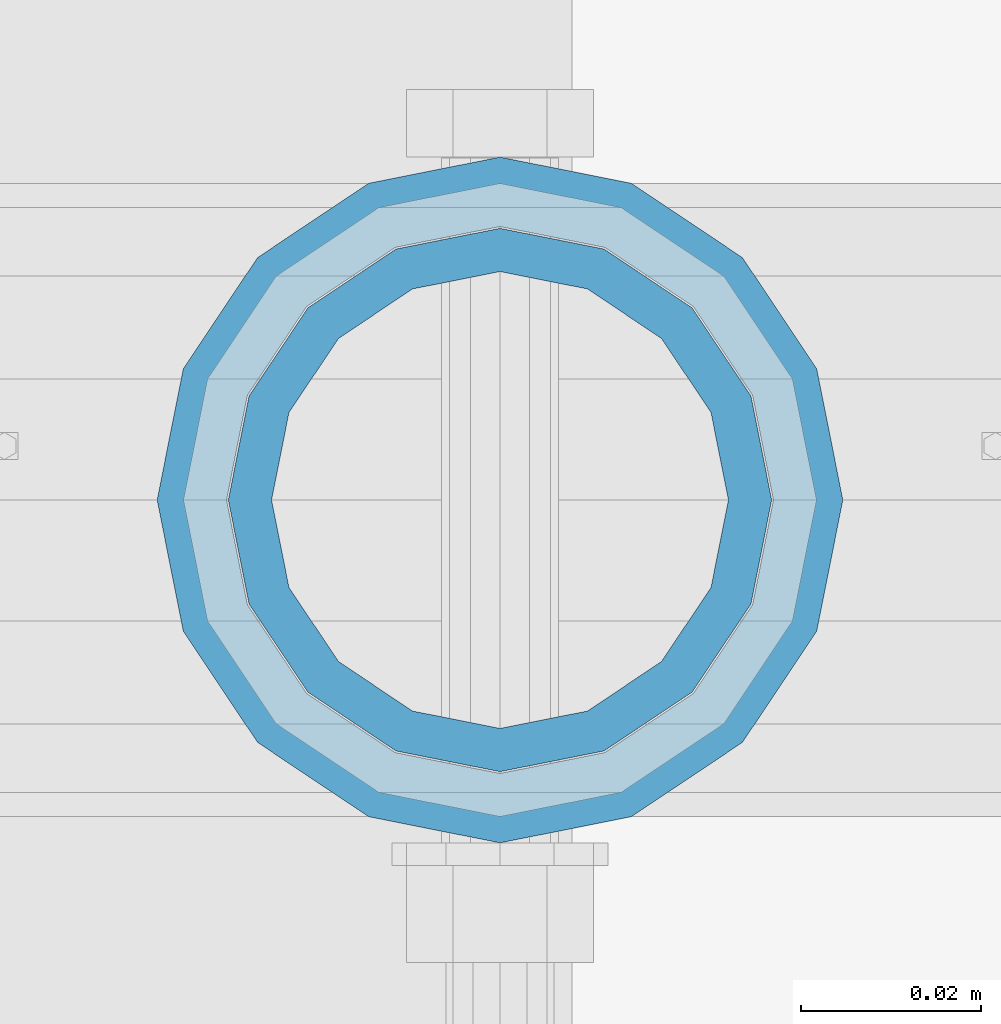
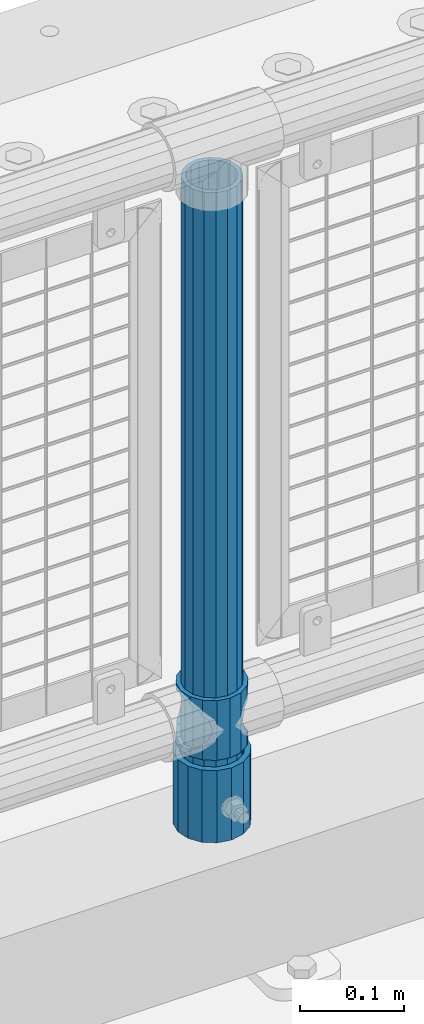
# One storey, part 92 of 270: 3 columns.
"""IFC2X3 building model written with IfcOpenShell, lengths in millimetres."""

from ifc_helpers import new_model, si_unit, frame, origin_with_axes, place, context, subcontext, project, spatial, faceted_brep, material, type_object, element, save


model = new_model("IFC2X3")

# Units and contexts
model_context = context("Model", 3, precision=1e-05, world=origin_with_axes())
body_context = subcontext(model_context, "Body", "Model", "MODEL_VIEW")
ifc_project = project(units=[si_unit("LENGTHUNIT", "METRE", prefix="MILLI"), si_unit("AREAUNIT", "SQUARE_METRE"), si_unit("VOLUMEUNIT", "CUBIC_METRE"), si_unit("MASSUNIT", "GRAM", prefix="KILO"), si_unit("TIMEUNIT", "SECOND"), si_unit("PLANEANGLEUNIT", "RADIAN"), si_unit("SOLIDANGLEUNIT", "STERADIAN"), si_unit("THERMODYNAMICTEMPERATUREUNIT", "DEGREE_CELSIUS"), si_unit("LUMINOUSINTENSITYUNIT", "LUMEN")], contexts=[model_context])

# Site, building, storey
site_placement = place(None, origin_with_axes())
site = spatial("IfcSite", under=ifc_project, at=site_placement, CompositionType="ELEMENT")
building_placement = place(site_placement, origin_with_axes())
building = spatial("IfcBuilding", under=site, at=building_placement, Name="Standard", CompositionType="ELEMENT")
storey_placement = place(building_placement, origin_with_axes())
storey = spatial("IfcBuildingStorey", under=building, at=storey_placement, Name="Undefined", CompositionType="ELEMENT", Elevation=0.0)

# Columns
ifc_material_1 = material()
column_type_1 = type_object("IfcColumnType", PredefinedType="NOTDEFINED")
column_1_placement = place(storey_placement, frame((12052.0, -16335.5, 168.02), z_axis=(-1.0, 0.0, 0.0), x_axis=(0.0, 0.0, 1.0)))
element("IfcColumn", 1, at=column_1_placement, inside=storey, type_object=column_type_1, material=ifc_material_1, context=body_context, shape_type="Brep", body=[
    faceted_brep([(0.0, -25.3500000000004, 0.0), (0.0, -23.4203461491616, 9.70102501045403), (760.0, -23.4203461491616, 9.70102501045403), (760.0, -25.3500000000004, 0.0), (0.0, -17.9251569030785, 17.9251569030785), (760.0, -17.9251569030785, 17.9251569030785), (0.0, -9.70102501045585, 23.4203461491597), (760.0, -9.70102501045585, 23.4203461491597), (0.0, 0.0, 25.3499999999985), (760.0, 0.0, 25.3499999999985), (0.0, 9.70102501045585, 23.4203461491597), (760.0, 9.70102501045585, 23.4203461491597), (0.0, 17.9251569030785, 17.9251569030785), (760.0, 17.9251569030785, 17.9251569030785), (0.0, 23.4203461491616, 9.70102501045403), (760.0, 23.4203461491616, 9.70102501045403), (0.0, 25.3500000000004, 0.0), (760.0, 25.3500000000004, 0.0), (0.0, 23.4203461491616, -9.70102501045403), (760.0, 23.4203461491616, -9.70102501045403), (0.0, 17.9251569030785, -17.9251569030785), (760.0, 17.9251569030785, -17.9251569030785), (0.0, 9.70102501045585, -23.4203461491597), (760.0, 9.70102501045585, -23.4203461491597), (0.0, 0.0, -25.3499999999985), (760.0, 0.0, -25.3499999999985), (0.0, -9.70102501045585, -23.4203461491597), (760.0, -9.70102501045585, -23.4203461491597), (0.0, -17.9251569030785, -17.9251569030785), (760.0, -17.9251569030785, -17.9251569030785), (0.0, -23.4203461491616, -9.70102501045403), (760.0, -23.4203461491616, -9.70102501045403), (0.0, -30.1499999999996, 0.0), (0.0, -27.8549679052157, -11.5379054858058), (760.0, -27.8549679052157, -11.5379054858058), (760.0, -30.1499999999996, 0.0), (0.0, -21.3192694527752, -21.3192694527752), (760.0, -21.3192694527752, -21.3192694527752), (0.0, -11.5379054858076, -27.8549679052157), (760.0, -11.5379054858076, -27.8549679052157), (0.0, 0.0, -30.1500000000015), (760.0, 0.0, -30.1500000000015), (0.0, 11.5379054858076, -27.8549679052157), (760.0, 11.5379054858076, -27.8549679052157), (0.0, 21.3192694527752, -21.3192694527752), (760.0, 21.3192694527752, -21.3192694527752), (0.0, 27.8549679052157, -11.5379054858058), (760.0, 27.8549679052157, -11.5379054858058), (0.0, 30.1499999999996, 0.0), (760.0, 30.1499999999996, 0.0), (0.0, 27.8549679052157, 11.5379054858058), (760.0, 27.8549679052157, 11.5379054858058), (0.0, 21.3192694527752, 21.3192694527752), (760.0, 21.3192694527752, 21.3192694527752), (0.0, 11.5379054858076, 27.8549679052157), (760.0, 11.5379054858076, 27.8549679052157), (0.0, 0.0, 30.1500000000015), (760.0, 0.0, 30.1500000000015), (0.0, -11.5379054858076, 27.8549679052157), (760.0, -11.5379054858076, 27.8549679052157), (0.0, -21.3192694527752, 21.3192694527752), (760.0, -21.3192694527752, 21.3192694527752), (0.0, -27.8549679052157, 11.5379054858058), (760.0, -27.8549679052157, 11.5379054858058)], [[[0, 1, 2, 3]], [[1, 4, 5, 2]], [[4, 6, 7, 5]], [[6, 8, 9, 7]], [[8, 10, 11, 9]], [[10, 12, 13, 11]], [[12, 14, 15, 13]], [[14, 16, 17, 15]], [[16, 18, 19, 17]], [[18, 20, 21, 19]], [[20, 22, 23, 21]], [[22, 24, 25, 23]], [[24, 26, 27, 25]], [[26, 28, 29, 27]], [[28, 30, 31, 29]], [[30, 0, 3, 31]], [[32, 33, 34, 35]], [[33, 36, 37, 34]], [[36, 38, 39, 37]], [[38, 40, 41, 39]], [[40, 42, 43, 41]], [[42, 44, 45, 43]], [[44, 46, 47, 45]], [[46, 48, 49, 47]], [[48, 50, 51, 49]], [[50, 52, 53, 51]], [[52, 54, 55, 53]], [[54, 56, 57, 55]], [[56, 58, 59, 57]], [[58, 60, 61, 59]], [[60, 62, 63, 61]], [[62, 32, 35, 63]], [[37, 39, 41, 43, 45, 47, 49, 51, 53, 55, 57, 59, 61, 63, 35, 34], [5, 7, 9, 11, 13, 15, 17, 19, 21, 23, 25, 27, 29, 31, 3, 2]], [[62, 60, 58, 56, 54, 52, 50, 48, 46, 44, 42, 40, 38, 36, 33, 32], [30, 28, 26, 24, 22, 20, 18, 16, 14, 12, 10, 8, 6, 4, 1, 0]]]),
])
column_type_2 = type_object("IfcColumnType", PredefinedType="NOTDEFINED")
column_2_placement = place(storey_placement, frame((12052.0, -16335.5, 168.02), z_axis=(0.0, 1.0, 0.0), x_axis=(0.0, 0.0, 1.0)))
element("IfcColumn", 2, at=column_2_placement, inside=storey, type_object=column_type_2, material=ifc_material_1, context=body_context, shape_type="Brep", body=[
    faceted_brep([(0.0, -31.75, 0.0), (0.0, -29.3331751572332, 12.1501989775916), (85.0, -29.3331751572332, 12.1501989775916), (85.0, -31.75, 0.0), (0.0, -22.4506403026717, 22.4506403026735), (85.0, -22.4506403026717, 22.4506403026735), (0.0, -12.1501989775934, 29.3331751572332), (85.0, -12.1501989775934, 29.3331751572332), (0.0, 0.0, 31.75), (85.0, 0.0, 31.75), (0.0, 12.1501989775934, 29.3331751572332), (85.0, 12.1501989775934, 29.3331751572332), (0.0, 22.4506403026717, 22.4506403026735), (85.0, 22.4506403026717, 22.4506403026735), (0.0, 29.3331751572332, 12.1501989775916), (85.0, 29.3331751572332, 12.1501989775916), (0.0, 31.75, 0.0), (85.0, 31.75, 0.0), (0.0, 29.3331751572332, -12.1501989775916), (85.0, 29.3331751572332, -12.1501989775916), (0.0, 22.4506403026717, -22.4506403026735), (85.0, 22.4506403026717, -22.4506403026735), (0.0, 12.1501989775934, -29.3331751572332), (85.0, 12.1501989775934, -29.3331751572332), (0.0, 0.0, -31.75), (85.0, 0.0, -31.75), (0.0, -12.1501989775934, -29.3331751572332), (85.0, -12.1501989775934, -29.3331751572332), (0.0, -22.4506403026717, -22.4506403026735), (85.0, -22.4506403026717, -22.4506403026735), (0.0, -29.3331751572332, -12.1501989775916), (85.0, -29.3331751572332, -12.1501989775916), (0.0, -38.0499999999993, 0.0), (0.0, -35.1536162120537, -14.561104601491), (85.0, -35.1536162120537, -14.561104601491), (85.0, -38.0499999999993, 0.0), (0.0, -26.9054130241493, -26.9054130241475), (85.0, -26.9054130241493, -26.9054130241475), (0.0, -14.5611046014928, -35.1536162120537), (85.0, -14.5611046014928, -35.1536162120537), (0.0, 0.0, -38.0499999999993), (85.0, 0.0, -38.0499999999993), (0.0, 14.5611046014928, -35.1536162120537), (85.0, 14.5611046014928, -35.1536162120537), (0.0, 26.9054130241493, -26.9054130241475), (85.0, 26.9054130241493, -26.9054130241475), (0.0, 35.1536162120537, -14.561104601491), (85.0, 35.1536162120537, -14.561104601491), (0.0, 38.0499999999993, 0.0), (85.0, 38.0499999999993, 0.0), (0.0, 35.1536162120537, 14.561104601491), (85.0, 35.1536162120537, 14.561104601491), (0.0, 26.9054130241493, 26.9054130241475), (85.0, 26.9054130241493, 26.9054130241475), (0.0, 14.5611046014928, 35.1536162120537), (85.0, 14.5611046014928, 35.1536162120537), (0.0, 0.0, 38.0499999999993), (85.0, 0.0, 38.0499999999993), (0.0, -14.5611046014928, 35.1536162120537), (85.0, -14.5611046014928, 35.1536162120537), (0.0, -26.9054130241493, 26.9054130241475), (85.0, -26.9054130241493, 26.9054130241475), (0.0, -35.1536162120537, 14.561104601491), (85.0, -35.1536162120537, 14.561104601491)], [[[0, 1, 2, 3]], [[1, 4, 5, 2]], [[4, 6, 7, 5]], [[6, 8, 9, 7]], [[8, 10, 11, 9]], [[10, 12, 13, 11]], [[12, 14, 15, 13]], [[14, 16, 17, 15]], [[16, 18, 19, 17]], [[18, 20, 21, 19]], [[20, 22, 23, 21]], [[22, 24, 25, 23]], [[24, 26, 27, 25]], [[26, 28, 29, 27]], [[28, 30, 31, 29]], [[30, 0, 3, 31]], [[32, 33, 34, 35]], [[33, 36, 37, 34]], [[36, 38, 39, 37]], [[38, 40, 41, 39]], [[40, 42, 43, 41]], [[42, 44, 45, 43]], [[44, 46, 47, 45]], [[46, 48, 49, 47]], [[48, 50, 51, 49]], [[50, 52, 53, 51]], [[52, 54, 55, 53]], [[54, 56, 57, 55]], [[56, 58, 59, 57]], [[58, 60, 61, 59]], [[60, 62, 63, 61]], [[62, 32, 35, 63]], [[37, 39, 41, 43, 45, 47, 49, 51, 53, 55, 57, 59, 61, 63, 35, 34], [5, 7, 9, 11, 13, 15, 17, 19, 21, 23, 25, 27, 29, 31, 3, 2]], [[62, 60, 58, 56, 54, 52, 50, 48, 46, 44, 42, 40, 38, 36, 33, 32], [30, 28, 26, 24, 22, 20, 18, 16, 14, 12, 10, 8, 6, 4, 1, 0]]]),
])
ifc_material_2 = material(Name="Misc_Undefined")
column_type_3 = type_object("IfcColumnType", PredefinedType="NOTDEFINED")
column_3_placement = place(storey_placement, frame((12052.0, -16335.5, 263.02), z_axis=(-1.0, 0.0, 0.0), x_axis=(0.0, 0.0, 1.0)))
element("IfcColumn", 3, at=column_3_placement, inside=storey, type_object=column_type_3, material=ifc_material_2, context=body_context, shape_type="Brep", body=[
    faceted_brep([(63.1897438117183, 11.6144421722802, -32.8397438117208), (63.1897438117183, 11.6144421722802, -28.0397438117179), (56.6106908090125, 21.4606908090118, -21.46069080901), (56.6106908090125, 21.4606908090118, -27.1226768591005), (61.9623795176767, 13.4513226476338, -32.4743655677703), (46.7644421722812, 28.0397438117179, -11.614442172282), (46.7644421722812, 28.0397438117179, -20.0882031229812), (51.5310424080071, 24.8548033587067, -24.8548033587067), (35.1500000000015, 30.35, 0.0), (35.1500000000008, 30.3500000000004, -16.6306603983612), (23.5355578277203, 28.0397438117179, -11.614442172282), (23.5355578277203, 28.0397438117179, -20.0882031229812), (18.7689575919954, 24.8548033587067, -24.8548033587067), (13.689309190989, 21.4606908090118, -21.46069080901), (13.689309190989, 21.4606908090118, -27.1226768591005), (8.33762048232484, 13.4513226476338, -32.4743655677703), (7.11025618828324, 11.6144421722802, -28.0397438117179), (7.11025618828324, 11.6144421722802, -32.8397438117208), (4.80000000000075, 0.0, -30.3499999999985), (4.80000000000075, 0.0, -35.1500000000015), (7.11025618828319, -11.6144421722802, -28.0397438117179), (7.11025618828319, -11.6144421722802, -32.8397438117172), (13.689309190989, -21.4606908090118, -21.46069080901), (13.689309190989, -21.4606908090118, -27.1226768591041), (8.33762048232484, -13.4513226476338, -32.4743655677703), (23.5355578277203, -28.0397438117179, -11.614442172282), (23.5355578277203, -28.0397438117179, -20.0882031229885), (18.7689575919954, -24.8548033587067, -24.8548033587067), (35.1500000000015, -30.35, 0.0), (35.1500000000008, -30.3500000000004, -16.6306603983721), (46.7644421722812, -28.0397438117179, -11.614442172282), (46.7644421722812, -28.0397438117179, -20.0882031229885), (51.5310424080071, -24.8548033587067, -24.8548033587067), (56.6106908090125, -21.4606908090118, -21.46069080901), (56.6106908090125, -21.4606908090118, -27.1226768591041), (61.9623795176767, -13.4513226476338, -32.4743655677703), (63.1897438117183, -11.6144421722802, -28.0397438117179), (63.1897438117183, -11.6144421722802, -32.8397438117172), (65.5000000000008, 0.0, -30.3499999999985), (65.5000000000008, 0.0, -35.1500000000015), (0.0, -28.0397438117179, -11.614442172282), (0.0, -30.3500000000004, 0.0), (0.0, -21.4606908090118, -21.46069080901), (0.0, -11.6144421722802, -28.0397438117179), (0.0, 0.0, -30.3499999999985), (0.0, 11.6144421722802, -28.0397438117179), (0.0, 21.4606908090118, -21.46069080901), (0.0, 28.0397438117179, -11.614442172282), (0.0, 30.3500000000004, 0.0), (0.0, 28.0397438117179, 11.614442172282), (23.5355578277192, 28.0397438117179, 11.614442172282), (0.0, 21.4606908090118, 21.46069080901), (13.6893091909879, 21.4606908090118, 21.46069080901), (0.0, 11.6144421722802, 28.0397438117179), (7.11025618828211, 11.6144421722802, 28.0397438117179), (0.0, 0.0, 30.3499999999985), (4.79999999999961, 0.0, 30.3499999999985), (0.0, -11.6144421722802, 28.0397438117179), (7.11025618828205, -11.6144421722802, 28.0397438117179), (0.0, -21.4606908090118, 21.46069080901), (13.6893091909879, -21.4606908090118, 21.46069080901), (0.0, -28.0397438117179, 11.614442172282), (23.5355578277191, -28.0397438117179, 11.614442172282), (0.0, -32.4743655677721, 13.4513226476338), (0.0, -35.1499999999996, 0.0), (70.2999999999993, -35.1499999999996, 0.0), (70.2999999999993, -32.4743655677721, 13.4513226476338), (0.0, 13.4513226476338, -32.4743655677703), (0.0, 24.8548033587067, -24.8548033587067), (0.0, 0.0, -35.1499999999996), (0.0, -13.4513226476338, -32.4743655677703), (0.0, -24.8548033587067, -24.8548033587067), (0.0, -24.8548033587067, 24.8548033587067), (0.0, -13.4513226476338, 32.4743655677703), (0.0, 0.0, 35.1499999999996), (0.0, 13.4513226476338, 32.4743655677703), (0.0, 24.8548033587067, 24.8548033587067), (0.0, 32.4743655677721, 13.4513226476338), (0.0, 35.1499999999996, 0.0), (0.0, 32.4743655677721, -13.4513226476338), (0.0, -32.4743655677721, -13.4513226476338), (70.2999999999993, 32.4743655677721, 13.4513226476338), (70.2999999999993, 35.1499999999996, 0.0), (70.2999999999993, 32.4743655677721, -13.4513226476338), (70.2999999999993, 24.8548033587067, -24.8548033587067), (70.2999999999993, 13.4513226476338, -32.4743655677703), (70.2999999999993, 0.0, -35.1500000000015), (70.2999999999993, -13.4513226476338, -32.4743655677703), (70.2999999999993, -24.8548033587067, -24.8548033587067), (70.2999999999993, -32.4743655677721, -13.4513226476338), (70.2999999999993, 28.0397438117179, 11.614442172282), (70.2999999999993, 21.4606908090118, 21.46069080901), (56.6106908090114, 21.4606908090118, 21.46069080901), (46.7644421722801, 28.0397438117179, 11.614442172282), (70.2999999999993, 11.6144421722802, 28.0397438117179), (63.1897438117172, 11.6144421722802, 28.0397438117179), (70.2999999999993, 0.0, 30.3499999999985), (65.4999999999997, 0.0, 30.3499999999985), (70.2999999999993, -11.6144421722802, 28.0397438117179), (63.1897438117172, -11.6144421722802, 28.0397438117179), (70.2999999999993, -21.4606908090118, 21.46069080901), (56.6106908090114, -21.4606908090118, 21.46069080901), (70.2999999999993, -28.0397438117179, 11.614442172282), (46.7644421722801, -28.0397438117179, 11.614442172282), (70.2999999999993, -11.6144421722802, -28.0397438117179), (70.2999999999993, 0.0, -30.3499999999985), (70.2999999999993, -21.4606908090118, -21.46069080901), (70.2999999999993, -28.0397438117179, -11.614442172282), (70.2999999999993, -30.3500000000004, 0.0), (70.2999999999993, 24.8548033587067, 24.8548033587067), (70.2999999999993, 13.4513226476338, 32.4743655677703), (70.2999999999993, 0.0, 35.1500000000015), (70.2999999999993, -13.4513226476338, 32.4743655677703), (70.2999999999993, -24.8548033587067, 24.8548033587067), (70.2999999999993, 30.3500000000004, 0.0), (70.2999999999993, 28.0397438117179, -11.614442172282), (70.2999999999993, 21.4606908090118, -21.46069080901), (70.2999999999993, 11.6144421722802, -28.0397438117179), (61.9623795176767, 13.4513226476338, 32.4743655677703), (51.5310424080039, 24.8548033587067, 24.8548033587067), (56.6106908090114, 21.4606908090118, 27.1226768591041), (65.4999999999997, 0.0, 35.1500000000015), (63.1897438117172, 11.6144421722802, 32.8397438117172), (63.1897438117172, -11.6144421722802, 32.8397438117172), (61.9623795176767, -13.4513226476338, 32.4743655677703), (56.6106908090114, -21.4606908090118, 27.1226768591077), (51.5310424080071, -24.8548033587067, 24.8548033587067), (18.7689575919954, -24.8548033587067, 24.8548033587067), (46.7644421722801, -28.0397438117179, 20.0882031229849), (35.1499999999996, -30.3500000000004, 16.6306603983649), (23.5355578277191, -28.0397438117179, 20.0882031229849), (8.33762048232262, -13.4513226476338, 32.4743655677703), (13.6893091909879, -21.4606908090118, 27.1226768591077), (4.79999999999961, 0.0, 35.1500000000015), (7.11025618828205, -11.6144421722802, 32.8397438117172), (7.11025618828211, 11.6144421722802, 32.8397438117172), (8.33762048232262, 13.4513226476338, 32.4743655677703), (13.6893091909879, 21.4606908090118, 27.1226768591041), (18.7689575919954, 24.8548033587067, 24.8548033587067), (23.5355578277192, 28.0397438117179, 20.0882031229885), (35.1499999999996, 30.3500000000004, 16.6306603983685), (46.7644421722801, 28.0397438117179, 20.0882031229885)], [[[0, 1, 2, 3, 4]], [[3, 2, 5, 6, 7]], [[6, 5, 8, 9]], [[9, 8, 10, 11]], [[12, 11, 10, 13, 14]], [[15, 14, 13, 16, 17]], [[17, 16, 18, 19]], [[19, 18, 20, 21]], [[21, 20, 22, 23, 24]], [[23, 22, 25, 26, 27]], [[26, 25, 28, 29]], [[29, 28, 30, 31]], [[32, 31, 30, 33, 34]], [[35, 34, 33, 36, 37]], [[37, 36, 38, 39]], [[39, 38, 1, 0]], [[40, 41, 28, 25]], [[42, 40, 25, 22]], [[43, 42, 22, 20]], [[44, 43, 20, 18]], [[45, 44, 18, 16]], [[46, 45, 16, 13]], [[47, 46, 13, 10]], [[48, 47, 10, 8]], [[49, 48, 8, 50]], [[51, 49, 50, 52]], [[53, 51, 52, 54]], [[55, 53, 54, 56]], [[57, 55, 56, 58]], [[59, 57, 58, 60]], [[61, 59, 60, 62]], [[41, 61, 62, 28]], [[63, 64, 65, 66]], [[67, 68, 12, 14, 15]], [[69, 67, 15, 17, 19]], [[24, 70, 69, 19, 21]], [[27, 71, 70, 24, 23]], [[63, 72, 73, 74, 75, 76, 77, 78, 79, 68, 67, 69, 70, 71, 80, 64], [40, 42, 43, 44, 45, 46, 47, 48, 49, 51, 53, 55, 57, 59, 61, 41]], [[78, 77, 81, 82]], [[79, 78, 82, 83]], [[68, 79, 83, 84, 7, 6, 9, 11, 12]], [[7, 84, 85, 4, 3]], [[4, 85, 86, 39, 0]], [[87, 88, 32, 34, 35]], [[86, 87, 35, 37, 39]], [[29, 31, 32, 88, 89, 80, 71, 27, 26]], [[64, 80, 89, 65]], [[90, 91, 92, 93]], [[91, 94, 95, 92]], [[94, 96, 97, 95]], [[96, 98, 99, 97]], [[98, 100, 101, 99]], [[100, 102, 103, 101]], [[104, 105, 38, 36]], [[106, 104, 36, 33]], [[107, 106, 33, 30]], [[108, 107, 30, 28]], [[102, 108, 28, 103]], [[88, 87, 86, 85, 84, 83, 82, 81, 109, 110, 111, 112, 113, 66, 65, 89], [100, 98, 96, 94, 91, 90, 114, 115, 116, 117, 105, 104, 106, 107, 108, 102]], [[118, 110, 109, 119, 120]], [[121, 111, 110, 118, 122]], [[112, 111, 121, 123, 124]], [[113, 112, 124, 125, 126]], [[127, 72, 63, 66, 113, 126, 128, 129, 130]], [[131, 73, 72, 127, 132]], [[133, 74, 73, 131, 134]], [[75, 74, 133, 135, 136]], [[76, 75, 136, 137, 138]], [[119, 109, 81, 77, 76, 138, 139, 140, 141]], [[92, 120, 119, 141, 93]], [[95, 122, 118, 120, 92]], [[97, 121, 122, 95]], [[99, 123, 121, 97]], [[101, 125, 124, 123, 99]], [[103, 128, 126, 125, 101]], [[28, 129, 128, 103]], [[62, 130, 129, 28]], [[60, 132, 127, 130, 62]], [[58, 134, 131, 132, 60]], [[56, 133, 134, 58]], [[54, 135, 133, 56]], [[52, 137, 136, 135, 54]], [[50, 139, 138, 137, 52]], [[8, 140, 139, 50]], [[93, 141, 140, 8]], [[114, 90, 93, 8]], [[115, 114, 8, 5]], [[116, 115, 5, 2]], [[117, 116, 2, 1]], [[105, 117, 1, 38]]]),
])

save(model, "model.ifc")
